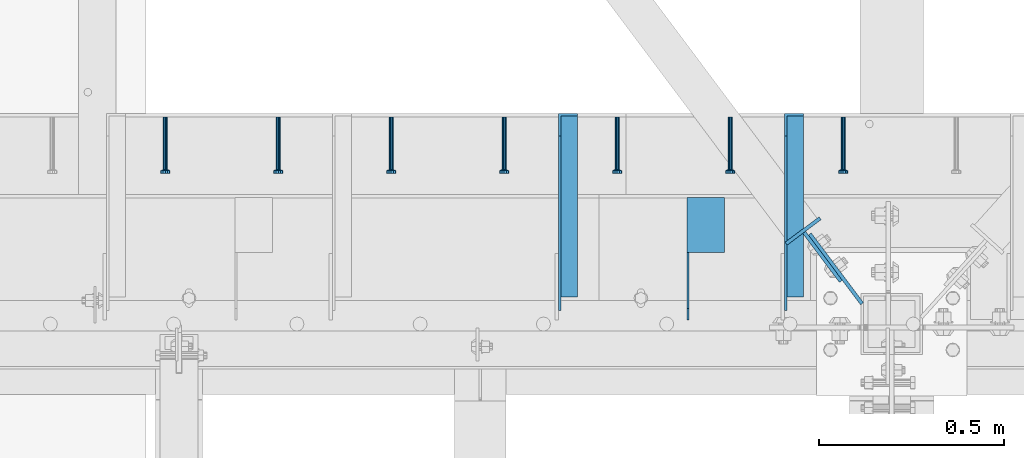
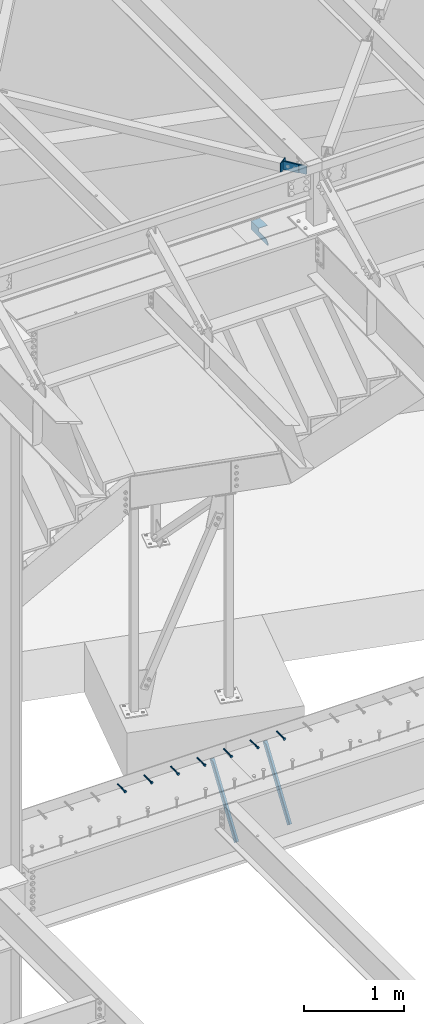
# One storey, part 1372 of 1763: 11 beams, 2 members, 11 elements without a shape of their own.
"""IFC2X3 building model written with IfcOpenShell, lengths in millimetres."""

from ifc_helpers import new_model, si_unit, frame, origin_with_axes, place, context, subcontext, project, spatial, faceted_brep, material, type_object, element, aggregate, save


model = new_model("IFC2X3")

# Units and contexts
model_context = context("Model", 3, precision=1e-05, world=origin_with_axes())
body_context = subcontext(model_context, "Body", "Model", "MODEL_VIEW")
ifc_project = project(units=[si_unit("LENGTHUNIT", "METRE", prefix="MILLI"), si_unit("AREAUNIT", "SQUARE_METRE"), si_unit("VOLUMEUNIT", "CUBIC_METRE"), si_unit("MASSUNIT", "GRAM", prefix="KILO"), si_unit("TIMEUNIT", "SECOND"), si_unit("PLANEANGLEUNIT", "RADIAN"), si_unit("SOLIDANGLEUNIT", "STERADIAN"), si_unit("THERMODYNAMICTEMPERATUREUNIT", "DEGREE_CELSIUS"), si_unit("LUMINOUSINTENSITYUNIT", "LUMEN")], contexts=[model_context])

# Site, building, storey
site_placement = place(None, origin_with_axes())
site = spatial("IfcSite", under=ifc_project, at=site_placement, CompositionType="ELEMENT")
building_placement = place(site_placement, origin_with_axes())
building = spatial("IfcBuilding", under=site, at=building_placement, Name="Undefined", CompositionType="ELEMENT")
storey_placement = place(building_placement, origin_with_axes())
storey = spatial("IfcBuildingStorey", under=building, at=storey_placement, Name="Undefined", CompositionType="ELEMENT", Elevation=0.0)

# Assembly, beam
assembly_1_placement = place(storey_placement, origin_with_axes())
assembly_1 = element("IfcElementAssembly", 1, at=assembly_1_placement, inside=storey, Name="HEADED STUD ANCHOR", AssemblyPlace="NOTDEFINED", PredefinedType="RIGID_FRAME")
ifc_material_1 = material(Name="STEEL/A108")
beam_type_1 = type_object("IfcBeamType", PredefinedType="NOTDEFINED")
beam_1_placement = place(assembly_1_placement, frame((-31240.2466486983, 52679.6000091552, 5264.23140606069), z_axis=(0.0, 0.0, 1.0), x_axis=(0.0, -1.0, 0.0)))
beam_1 = element("IfcBeam", 2, at=beam_1_placement, type_object=beam_type_1, material=ifc_material_1, Name="HEADED STUD ANCHOR", context=body_context, shape_type="Brep", body=[
    faceted_brep([(0.0, -3.1800000667572, 5.5), (0.0, -5.5, 3.1800000667572), (141.732000000002, -5.5, 3.1800000667572), (141.732000000002, -3.1800000667572, 5.5), (0.0, -6.34999999999491, 1.45519152283669e-11), (141.732000000002, -6.34999990463257, 0.0), (0.0, -5.5, -3.1800000667572), (141.732000000002, -5.5, -3.1800000667572), (0.0, -3.1800000667572, -5.5), (141.732000000002, -3.1800000667572, -5.5), (0.0, 0.0, -6.34999990463257), (141.732000000002, 0.0, -6.34999990463257), (0.0, 3.1800000667572, -5.5), (141.732000000002, 3.1800000667572, -5.5), (0.0, 5.5, -3.1800000667572), (141.732000000002, 5.5, -3.1800000667572), (0.0, 6.34999999999491, -2.91038304567337e-11), (141.732000000002, 6.34999990463257, 0.0), (0.0, 5.5, 3.1800000667572), (141.732000000002, 5.5, 3.1800000667572), (0.0, 3.1800000667572, 5.5), (141.732000000002, 3.1800000667572, 5.5), (0.0, 0.0, 6.34999990463257), (141.732000000002, 0.0, 6.34999990463257), (144.780000000001, -10.9899997711182, 6.34999990463257), (144.780000000001, -6.34000015258789, 10.9899997711182), (144.780000000001, -12.6999998092651, 0.0), (144.780000000001, -10.9899997711182, -6.34999990463257), (144.780000000001, -6.34000015258789, -10.9899997711182), (144.780000000001, 0.0, -12.6899995803833), (144.780000000001, 6.34000015258789, -10.9899997711182), (144.780000000001, 10.9899997711182, -6.34999990463257), (144.780000000001, 12.6999998092651, 0.0), (144.780000000001, 10.9899997711182, 6.34999990463257), (144.780000000001, 6.34000015258789, 10.9899997711182), (144.780000000001, 0.0, 12.6899995803833), (152.400000000001, -10.9899997711182, 6.34999990463257), (152.400000000001, -6.34000015258789, 10.9899997711182), (152.400000000001, -12.6999998092651, 0.0), (152.400000000001, -10.9899997711182, -6.34999990463257), (152.400000000001, -6.34000015258789, -10.9899997711182), (152.400000000001, 0.0, -12.6899995803833), (152.400000000001, 6.34000015258789, -10.9899997711182), (152.400000000001, 10.9899997711182, -6.34999990463257), (152.400000000001, 12.6999998092651, 0.0), (152.400000000001, 10.9899997711182, 6.34999990463257), (152.400000000001, 6.34000015258789, 10.9899997711182), (152.400000000001, 0.0, 12.6899995803833)], [[[0, 1, 2, 3]], [[1, 4, 5, 2]], [[4, 6, 7, 5]], [[6, 8, 9, 7]], [[8, 10, 11, 9]], [[10, 12, 13, 11]], [[12, 14, 15, 13]], [[14, 16, 17, 15]], [[16, 18, 19, 17]], [[18, 20, 21, 19]], [[20, 22, 23, 21]], [[22, 0, 3, 23]], [[22, 20, 18, 16, 14, 12, 10, 8, 6, 4, 1, 0]], [[3, 2, 24, 25]], [[2, 5, 26, 24]], [[5, 7, 27, 26]], [[7, 9, 28, 27]], [[9, 11, 29, 28]], [[11, 13, 30, 29]], [[13, 15, 31, 30]], [[15, 17, 32, 31]], [[17, 19, 33, 32]], [[19, 21, 34, 33]], [[21, 23, 35, 34]], [[23, 3, 25, 35]], [[25, 24, 36, 37]], [[24, 26, 38, 36]], [[26, 27, 39, 38]], [[27, 28, 40, 39]], [[28, 29, 41, 40]], [[29, 30, 42, 41]], [[30, 31, 43, 42]], [[31, 32, 44, 43]], [[32, 33, 45, 44]], [[33, 34, 46, 45]], [[34, 35, 47, 46]], [[35, 25, 37, 47]], [[38, 39, 40, 41, 42, 43, 44, 45, 46, 47, 37, 36]]]),
])
aggregate(assembly_1, [beam_1])

assembly_2_placement = place(storey_placement, origin_with_axes())
assembly_2 = element("IfcElementAssembly", 3, at=assembly_2_placement, inside=storey, Name="HEADED STUD ANCHOR", AssemblyPlace="NOTDEFINED", PredefinedType="RIGID_FRAME")
beam_2_placement = place(assembly_2_placement, frame((-31545.0466486983, 52679.6000091552, 5264.23140606069), z_axis=(0.0, 0.0, 1.0), x_axis=(0.0, -1.0, 0.0)))
beam_2 = element("IfcBeam", 4, at=beam_2_placement, type_object=beam_type_1, material=ifc_material_1, Name="HEADED STUD ANCHOR", context=body_context, shape_type="Brep", body=[
    faceted_brep([(0.0, -3.1800000667572, 5.5), (0.0, -5.5, 3.1800000667572), (141.732000000002, -5.5, 3.1800000667572), (141.732000000002, -3.1800000667572, 5.5), (0.0, -6.34999999999491, 1.45519152283669e-11), (141.732000000002, -6.34999990463257, 0.0), (0.0, -5.5, -3.1800000667572), (141.732000000002, -5.5, -3.1800000667572), (0.0, -3.1800000667572, -5.5), (141.732000000002, -3.1800000667572, -5.5), (0.0, 0.0, -6.34999990463257), (141.732000000002, 0.0, -6.34999990463257), (0.0, 3.1800000667572, -5.5), (141.732000000002, 3.1800000667572, -5.5), (0.0, 5.5, -3.1800000667572), (141.732000000002, 5.5, -3.1800000667572), (0.0, 6.34999999999491, -2.91038304567337e-11), (141.732000000002, 6.34999990463257, 0.0), (0.0, 5.5, 3.1800000667572), (141.732000000002, 5.5, 3.1800000667572), (0.0, 3.1800000667572, 5.5), (141.732000000002, 3.1800000667572, 5.5), (0.0, 0.0, 6.34999990463257), (141.732000000002, 0.0, 6.34999990463257), (144.780000000001, -10.9899997711182, 6.34999990463257), (144.780000000001, -6.34000015258789, 10.9899997711182), (144.780000000001, -12.6999998092651, 0.0), (144.780000000001, -10.9899997711182, -6.34999990463257), (144.780000000001, -6.34000015258789, -10.9899997711182), (144.780000000001, 0.0, -12.6899995803833), (144.780000000001, 6.34000015258789, -10.9899997711182), (144.780000000001, 10.9899997711182, -6.34999990463257), (144.780000000001, 12.6999998092651, 0.0), (144.780000000001, 10.9899997711182, 6.34999990463257), (144.780000000001, 6.34000015258789, 10.9899997711182), (144.780000000001, 0.0, 12.6899995803833), (152.400000000001, -10.9899997711182, 6.34999990463257), (152.400000000001, -6.34000015258789, 10.9899997711182), (152.400000000001, -12.6999998092651, 0.0), (152.400000000001, -10.9899997711182, -6.34999990463257), (152.400000000001, -6.34000015258789, -10.9899997711182), (152.400000000001, 0.0, -12.6899995803833), (152.400000000001, 6.34000015258789, -10.9899997711182), (152.400000000001, 10.9899997711182, -6.34999990463257), (152.400000000001, 12.6999998092651, 0.0), (152.400000000001, 10.9899997711182, 6.34999990463257), (152.400000000001, 6.34000015258789, 10.9899997711182), (152.400000000001, 0.0, 12.6899995803833)], [[[0, 1, 2, 3]], [[1, 4, 5, 2]], [[4, 6, 7, 5]], [[6, 8, 9, 7]], [[8, 10, 11, 9]], [[10, 12, 13, 11]], [[12, 14, 15, 13]], [[14, 16, 17, 15]], [[16, 18, 19, 17]], [[18, 20, 21, 19]], [[20, 22, 23, 21]], [[22, 0, 3, 23]], [[22, 20, 18, 16, 14, 12, 10, 8, 6, 4, 1, 0]], [[3, 2, 24, 25]], [[2, 5, 26, 24]], [[5, 7, 27, 26]], [[7, 9, 28, 27]], [[9, 11, 29, 28]], [[11, 13, 30, 29]], [[13, 15, 31, 30]], [[15, 17, 32, 31]], [[17, 19, 33, 32]], [[19, 21, 34, 33]], [[21, 23, 35, 34]], [[23, 3, 25, 35]], [[25, 24, 36, 37]], [[24, 26, 38, 36]], [[26, 27, 39, 38]], [[27, 28, 40, 39]], [[28, 29, 41, 40]], [[29, 30, 42, 41]], [[30, 31, 43, 42]], [[31, 32, 44, 43]], [[32, 33, 45, 44]], [[33, 34, 46, 45]], [[34, 35, 47, 46]], [[35, 25, 37, 47]], [[38, 39, 40, 41, 42, 43, 44, 45, 46, 47, 37, 36]]]),
])
aggregate(assembly_2, [beam_2])

assembly_3_placement = place(storey_placement, origin_with_axes())
assembly_3 = element("IfcElementAssembly", 5, at=assembly_3_placement, inside=storey, Name="HEADED STUD ANCHOR", AssemblyPlace="NOTDEFINED", PredefinedType="RIGID_FRAME")
beam_3_placement = place(assembly_3_placement, frame((-31849.8466486983, 52679.6000091552, 5264.23140606069), z_axis=(0.0, 0.0, 1.0), x_axis=(0.0, -1.0, 0.0)))
beam_3 = element("IfcBeam", 6, at=beam_3_placement, type_object=beam_type_1, material=ifc_material_1, Name="HEADED STUD ANCHOR", context=body_context, shape_type="Brep", body=[
    faceted_brep([(0.0, -3.1800000667572, 5.5), (0.0, -5.5, 3.1800000667572), (141.732000000002, -5.5, 3.1800000667572), (141.732000000002, -3.1800000667572, 5.5), (0.0, -6.34999999999491, 1.45519152283669e-11), (141.732000000002, -6.34999990463257, 0.0), (0.0, -5.5, -3.1800000667572), (141.732000000002, -5.5, -3.1800000667572), (0.0, -3.1800000667572, -5.5), (141.732000000002, -3.1800000667572, -5.5), (0.0, 0.0, -6.34999990463257), (141.732000000002, 0.0, -6.34999990463257), (0.0, 3.1800000667572, -5.5), (141.732000000002, 3.1800000667572, -5.5), (0.0, 5.5, -3.1800000667572), (141.732000000002, 5.5, -3.1800000667572), (0.0, 6.34999999999491, -2.91038304567337e-11), (141.732000000002, 6.34999990463257, 0.0), (0.0, 5.5, 3.1800000667572), (141.732000000002, 5.5, 3.1800000667572), (0.0, 3.1800000667572, 5.5), (141.732000000002, 3.1800000667572, 5.5), (0.0, 0.0, 6.34999990463257), (141.732000000002, 0.0, 6.34999990463257), (144.780000000001, -10.9899997711182, 6.34999990463257), (144.780000000001, -6.34000015258789, 10.9899997711182), (144.780000000001, -12.6999998092651, 0.0), (144.780000000001, -10.9899997711182, -6.34999990463257), (144.780000000001, -6.34000015258789, -10.9899997711182), (144.780000000001, 0.0, -12.6899995803833), (144.780000000001, 6.34000015258789, -10.9899997711182), (144.780000000001, 10.9899997711182, -6.34999990463257), (144.780000000001, 12.6999998092651, 0.0), (144.780000000001, 10.9899997711182, 6.34999990463257), (144.780000000001, 6.34000015258789, 10.9899997711182), (144.780000000001, 0.0, 12.6899995803833), (152.400000000001, -10.9899997711182, 6.34999990463257), (152.400000000001, -6.34000015258789, 10.9899997711182), (152.400000000001, -12.6999998092651, 0.0), (152.400000000001, -10.9899997711182, -6.34999990463257), (152.400000000001, -6.34000015258789, -10.9899997711182), (152.400000000001, 0.0, -12.6899995803833), (152.400000000001, 6.34000015258789, -10.9899997711182), (152.400000000001, 10.9899997711182, -6.34999990463257), (152.400000000001, 12.6999998092651, 0.0), (152.400000000001, 10.9899997711182, 6.34999990463257), (152.400000000001, 6.34000015258789, 10.9899997711182), (152.400000000001, 0.0, 12.6899995803833)], [[[0, 1, 2, 3]], [[1, 4, 5, 2]], [[4, 6, 7, 5]], [[6, 8, 9, 7]], [[8, 10, 11, 9]], [[10, 12, 13, 11]], [[12, 14, 15, 13]], [[14, 16, 17, 15]], [[16, 18, 19, 17]], [[18, 20, 21, 19]], [[20, 22, 23, 21]], [[22, 0, 3, 23]], [[22, 20, 18, 16, 14, 12, 10, 8, 6, 4, 1, 0]], [[3, 2, 24, 25]], [[2, 5, 26, 24]], [[5, 7, 27, 26]], [[7, 9, 28, 27]], [[9, 11, 29, 28]], [[11, 13, 30, 29]], [[13, 15, 31, 30]], [[15, 17, 32, 31]], [[17, 19, 33, 32]], [[19, 21, 34, 33]], [[21, 23, 35, 34]], [[23, 3, 25, 35]], [[25, 24, 36, 37]], [[24, 26, 38, 36]], [[26, 27, 39, 38]], [[27, 28, 40, 39]], [[28, 29, 41, 40]], [[29, 30, 42, 41]], [[30, 31, 43, 42]], [[31, 32, 44, 43]], [[32, 33, 45, 44]], [[33, 34, 46, 45]], [[34, 35, 47, 46]], [[35, 25, 37, 47]], [[38, 39, 40, 41, 42, 43, 44, 45, 46, 47, 37, 36]]]),
])
aggregate(assembly_3, [beam_3])

assembly_4_placement = place(storey_placement, origin_with_axes())
assembly_4 = element("IfcElementAssembly", 7, at=assembly_4_placement, inside=storey, Name="HEADED STUD ANCHOR", AssemblyPlace="NOTDEFINED", PredefinedType="RIGID_FRAME")
beam_4_placement = place(assembly_4_placement, frame((-32154.6466486983, 52679.6000091552, 5264.23140606069), z_axis=(0.0, 0.0, 1.0), x_axis=(0.0, -1.0, 0.0)))
beam_4 = element("IfcBeam", 8, at=beam_4_placement, type_object=beam_type_1, material=ifc_material_1, Name="HEADED STUD ANCHOR", context=body_context, shape_type="Brep", body=[
    faceted_brep([(0.0, -3.1800000667572, 5.5), (0.0, -5.5, 3.1800000667572), (141.732000000002, -5.5, 3.1800000667572), (141.732000000002, -3.1800000667572, 5.5), (0.0, -6.34999999999491, 1.45519152283669e-11), (141.732000000002, -6.34999990463257, 0.0), (0.0, -5.5, -3.1800000667572), (141.732000000002, -5.5, -3.1800000667572), (0.0, -3.1800000667572, -5.5), (141.732000000002, -3.1800000667572, -5.5), (0.0, 0.0, -6.34999990463257), (141.732000000002, 0.0, -6.34999990463257), (0.0, 3.1800000667572, -5.5), (141.732000000002, 3.1800000667572, -5.5), (0.0, 5.5, -3.1800000667572), (141.732000000002, 5.5, -3.1800000667572), (0.0, 6.34999999999491, -2.91038304567337e-11), (141.732000000002, 6.34999990463257, 0.0), (0.0, 5.5, 3.1800000667572), (141.732000000002, 5.5, 3.1800000667572), (0.0, 3.1800000667572, 5.5), (141.732000000002, 3.1800000667572, 5.5), (0.0, 0.0, 6.34999990463257), (141.732000000002, 0.0, 6.34999990463257), (144.780000000001, -10.9899997711182, 6.34999990463257), (144.780000000001, -6.34000015258789, 10.9899997711182), (144.780000000001, -12.6999998092651, 0.0), (144.780000000001, -10.9899997711182, -6.34999990463257), (144.780000000001, -6.34000015258789, -10.9899997711182), (144.780000000001, 0.0, -12.6899995803833), (144.780000000001, 6.34000015258789, -10.9899997711182), (144.780000000001, 10.9899997711182, -6.34999990463257), (144.780000000001, 12.6999998092651, 0.0), (144.780000000001, 10.9899997711182, 6.34999990463257), (144.780000000001, 6.34000015258789, 10.9899997711182), (144.780000000001, 0.0, 12.6899995803833), (152.400000000001, -10.9899997711182, 6.34999990463257), (152.400000000001, -6.34000015258789, 10.9899997711182), (152.400000000001, -12.6999998092651, 0.0), (152.400000000001, -10.9899997711182, -6.34999990463257), (152.400000000001, -6.34000015258789, -10.9899997711182), (152.400000000001, 0.0, -12.6899995803833), (152.400000000001, 6.34000015258789, -10.9899997711182), (152.400000000001, 10.9899997711182, -6.34999990463257), (152.400000000001, 12.6999998092651, 0.0), (152.400000000001, 10.9899997711182, 6.34999990463257), (152.400000000001, 6.34000015258789, 10.9899997711182), (152.400000000001, 0.0, 12.6899995803833)], [[[0, 1, 2, 3]], [[1, 4, 5, 2]], [[4, 6, 7, 5]], [[6, 8, 9, 7]], [[8, 10, 11, 9]], [[10, 12, 13, 11]], [[12, 14, 15, 13]], [[14, 16, 17, 15]], [[16, 18, 19, 17]], [[18, 20, 21, 19]], [[20, 22, 23, 21]], [[22, 0, 3, 23]], [[22, 20, 18, 16, 14, 12, 10, 8, 6, 4, 1, 0]], [[3, 2, 24, 25]], [[2, 5, 26, 24]], [[5, 7, 27, 26]], [[7, 9, 28, 27]], [[9, 11, 29, 28]], [[11, 13, 30, 29]], [[13, 15, 31, 30]], [[15, 17, 32, 31]], [[17, 19, 33, 32]], [[19, 21, 34, 33]], [[21, 23, 35, 34]], [[23, 3, 25, 35]], [[25, 24, 36, 37]], [[24, 26, 38, 36]], [[26, 27, 39, 38]], [[27, 28, 40, 39]], [[28, 29, 41, 40]], [[29, 30, 42, 41]], [[30, 31, 43, 42]], [[31, 32, 44, 43]], [[32, 33, 45, 44]], [[33, 34, 46, 45]], [[34, 35, 47, 46]], [[35, 25, 37, 47]], [[38, 39, 40, 41, 42, 43, 44, 45, 46, 47, 37, 36]]]),
])
aggregate(assembly_4, [beam_4])

assembly_5_placement = place(storey_placement, origin_with_axes())
assembly_5 = element("IfcElementAssembly", 9, at=assembly_5_placement, inside=storey, Name="HEADED STUD ANCHOR", AssemblyPlace="NOTDEFINED", PredefinedType="RIGID_FRAME")
beam_5_placement = place(assembly_5_placement, frame((-32459.4466486983, 52679.6000091552, 5264.23140606069), z_axis=(0.0, 0.0, 1.0), x_axis=(0.0, -1.0, 0.0)))
beam_5 = element("IfcBeam", 10, at=beam_5_placement, type_object=beam_type_1, material=ifc_material_1, Name="HEADED STUD ANCHOR", context=body_context, shape_type="Brep", body=[
    faceted_brep([(0.0, -3.1800000667572, 5.5), (0.0, -5.5, 3.1800000667572), (141.732000000002, -5.5, 3.1800000667572), (141.732000000002, -3.1800000667572, 5.5), (0.0, -6.34999999999491, 1.45519152283669e-11), (141.732000000002, -6.34999990463257, 0.0), (0.0, -5.5, -3.1800000667572), (141.732000000002, -5.5, -3.1800000667572), (0.0, -3.1800000667572, -5.5), (141.732000000002, -3.1800000667572, -5.5), (0.0, 0.0, -6.34999990463257), (141.732000000002, 0.0, -6.34999990463257), (0.0, 3.1800000667572, -5.5), (141.732000000002, 3.1800000667572, -5.5), (0.0, 5.5, -3.1800000667572), (141.732000000002, 5.5, -3.1800000667572), (0.0, 6.34999999999491, -2.91038304567337e-11), (141.732000000002, 6.34999990463257, 0.0), (0.0, 5.5, 3.1800000667572), (141.732000000002, 5.5, 3.1800000667572), (0.0, 3.1800000667572, 5.5), (141.732000000002, 3.1800000667572, 5.5), (0.0, 0.0, 6.34999990463257), (141.732000000002, 0.0, 6.34999990463257), (144.780000000001, -10.9899997711182, 6.34999990463257), (144.780000000001, -6.34000015258789, 10.9899997711182), (144.780000000001, -12.6999998092651, 0.0), (144.780000000001, -10.9899997711182, -6.34999990463257), (144.780000000001, -6.34000015258789, -10.9899997711182), (144.780000000001, 0.0, -12.6899995803833), (144.780000000001, 6.34000015258789, -10.9899997711182), (144.780000000001, 10.9899997711182, -6.34999990463257), (144.780000000001, 12.6999998092651, 0.0), (144.780000000001, 10.9899997711182, 6.34999990463257), (144.780000000001, 6.34000015258789, 10.9899997711182), (144.780000000001, 0.0, 12.6899995803833), (152.400000000001, -10.9899997711182, 6.34999990463257), (152.400000000001, -6.34000015258789, 10.9899997711182), (152.400000000001, -12.6999998092651, 0.0), (152.400000000001, -10.9899997711182, -6.34999990463257), (152.400000000001, -6.34000015258789, -10.9899997711182), (152.400000000001, 0.0, -12.6899995803833), (152.400000000001, 6.34000015258789, -10.9899997711182), (152.400000000001, 10.9899997711182, -6.34999990463257), (152.400000000001, 12.6999998092651, 0.0), (152.400000000001, 10.9899997711182, 6.34999990463257), (152.400000000001, 6.34000015258789, 10.9899997711182), (152.400000000001, 0.0, 12.6899995803833)], [[[0, 1, 2, 3]], [[1, 4, 5, 2]], [[4, 6, 7, 5]], [[6, 8, 9, 7]], [[8, 10, 11, 9]], [[10, 12, 13, 11]], [[12, 14, 15, 13]], [[14, 16, 17, 15]], [[16, 18, 19, 17]], [[18, 20, 21, 19]], [[20, 22, 23, 21]], [[22, 0, 3, 23]], [[22, 20, 18, 16, 14, 12, 10, 8, 6, 4, 1, 0]], [[3, 2, 24, 25]], [[2, 5, 26, 24]], [[5, 7, 27, 26]], [[7, 9, 28, 27]], [[9, 11, 29, 28]], [[11, 13, 30, 29]], [[13, 15, 31, 30]], [[15, 17, 32, 31]], [[17, 19, 33, 32]], [[19, 21, 34, 33]], [[21, 23, 35, 34]], [[23, 3, 25, 35]], [[25, 24, 36, 37]], [[24, 26, 38, 36]], [[26, 27, 39, 38]], [[27, 28, 40, 39]], [[28, 29, 41, 40]], [[29, 30, 42, 41]], [[30, 31, 43, 42]], [[31, 32, 44, 43]], [[32, 33, 45, 44]], [[33, 34, 46, 45]], [[34, 35, 47, 46]], [[35, 25, 37, 47]], [[38, 39, 40, 41, 42, 43, 44, 45, 46, 47, 37, 36]]]),
])
aggregate(assembly_5, [beam_5])

assembly_6_placement = place(storey_placement, origin_with_axes())
assembly_6 = element("IfcElementAssembly", 11, at=assembly_6_placement, inside=storey, Name="HEADED STUD ANCHOR", AssemblyPlace="NOTDEFINED", PredefinedType="RIGID_FRAME")
beam_6_placement = place(assembly_6_placement, frame((-32764.2466486983, 52679.6000091552, 5264.23140606069), z_axis=(0.0, 0.0, 1.0), x_axis=(0.0, -1.0, 0.0)))
beam_6 = element("IfcBeam", 12, at=beam_6_placement, type_object=beam_type_1, material=ifc_material_1, Name="HEADED STUD ANCHOR", context=body_context, shape_type="Brep", body=[
    faceted_brep([(0.0, -3.1800000667572, 5.5), (0.0, -5.5, 3.1800000667572), (141.732000000002, -5.5, 3.1800000667572), (141.732000000002, -3.1800000667572, 5.5), (0.0, -6.34999999999491, 1.45519152283669e-11), (141.732000000002, -6.34999990463257, 0.0), (0.0, -5.5, -3.1800000667572), (141.732000000002, -5.5, -3.1800000667572), (0.0, -3.1800000667572, -5.5), (141.732000000002, -3.1800000667572, -5.5), (0.0, 0.0, -6.34999990463257), (141.732000000002, 0.0, -6.34999990463257), (0.0, 3.1800000667572, -5.5), (141.732000000002, 3.1800000667572, -5.5), (0.0, 5.5, -3.1800000667572), (141.732000000002, 5.5, -3.1800000667572), (0.0, 6.34999999999491, -2.91038304567337e-11), (141.732000000002, 6.34999990463257, 0.0), (0.0, 5.5, 3.1800000667572), (141.732000000002, 5.5, 3.1800000667572), (0.0, 3.1800000667572, 5.5), (141.732000000002, 3.1800000667572, 5.5), (0.0, 0.0, 6.34999990463257), (141.732000000002, 0.0, 6.34999990463257), (144.780000000001, -10.9899997711182, 6.34999990463257), (144.780000000001, -6.34000015258789, 10.9899997711182), (144.780000000001, -12.6999998092651, 0.0), (144.780000000001, -10.9899997711182, -6.34999990463257), (144.780000000001, -6.34000015258789, -10.9899997711182), (144.780000000001, 0.0, -12.6899995803833), (144.780000000001, 6.34000015258789, -10.9899997711182), (144.780000000001, 10.9899997711182, -6.34999990463257), (144.780000000001, 12.6999998092651, 0.0), (144.780000000001, 10.9899997711182, 6.34999990463257), (144.780000000001, 6.34000015258789, 10.9899997711182), (144.780000000001, 0.0, 12.6899995803833), (152.400000000001, -10.9899997711182, 6.34999990463257), (152.400000000001, -6.34000015258789, 10.9899997711182), (152.400000000001, -12.6999998092651, 0.0), (152.400000000001, -10.9899997711182, -6.34999990463257), (152.400000000001, -6.34000015258789, -10.9899997711182), (152.400000000001, 0.0, -12.6899995803833), (152.400000000001, 6.34000015258789, -10.9899997711182), (152.400000000001, 10.9899997711182, -6.34999990463257), (152.400000000001, 12.6999998092651, 0.0), (152.400000000001, 10.9899997711182, 6.34999990463257), (152.400000000001, 6.34000015258789, 10.9899997711182), (152.400000000001, 0.0, 12.6899995803833)], [[[0, 1, 2, 3]], [[1, 4, 5, 2]], [[4, 6, 7, 5]], [[6, 8, 9, 7]], [[8, 10, 11, 9]], [[10, 12, 13, 11]], [[12, 14, 15, 13]], [[14, 16, 17, 15]], [[16, 18, 19, 17]], [[18, 20, 21, 19]], [[20, 22, 23, 21]], [[22, 0, 3, 23]], [[22, 20, 18, 16, 14, 12, 10, 8, 6, 4, 1, 0]], [[3, 2, 24, 25]], [[2, 5, 26, 24]], [[5, 7, 27, 26]], [[7, 9, 28, 27]], [[9, 11, 29, 28]], [[11, 13, 30, 29]], [[13, 15, 31, 30]], [[15, 17, 32, 31]], [[17, 19, 33, 32]], [[19, 21, 34, 33]], [[21, 23, 35, 34]], [[23, 3, 25, 35]], [[25, 24, 36, 37]], [[24, 26, 38, 36]], [[26, 27, 39, 38]], [[27, 28, 40, 39]], [[28, 29, 41, 40]], [[29, 30, 42, 41]], [[30, 31, 43, 42]], [[31, 32, 44, 43]], [[32, 33, 45, 44]], [[33, 34, 46, 45]], [[34, 35, 47, 46]], [[35, 25, 37, 47]], [[38, 39, 40, 41, 42, 43, 44, 45, 46, 47, 37, 36]]]),
])
aggregate(assembly_6, [beam_6])

assembly_7_placement = place(storey_placement, origin_with_axes())
assembly_7 = element("IfcElementAssembly", 13, at=assembly_7_placement, inside=storey, Name="HEADED STUD ANCHOR", AssemblyPlace="NOTDEFINED", PredefinedType="RIGID_FRAME")
beam_7_placement = place(assembly_7_placement, frame((-33069.0466486983, 52679.6000091552, 5264.23140606069), z_axis=(0.0, 0.0, 1.0), x_axis=(0.0, -1.0, 0.0)))
beam_7 = element("IfcBeam", 14, at=beam_7_placement, type_object=beam_type_1, material=ifc_material_1, Name="HEADED STUD ANCHOR", context=body_context, shape_type="Brep", body=[
    faceted_brep([(0.0, -3.1800000667572, 5.5), (0.0, -5.5, 3.1800000667572), (141.732000000002, -5.5, 3.1800000667572), (141.732000000002, -3.1800000667572, 5.5), (0.0, -6.34999999999491, 1.45519152283669e-11), (141.732000000002, -6.34999990463257, 0.0), (0.0, -5.5, -3.1800000667572), (141.732000000002, -5.5, -3.1800000667572), (0.0, -3.1800000667572, -5.5), (141.732000000002, -3.1800000667572, -5.5), (0.0, 0.0, -6.34999990463257), (141.732000000002, 0.0, -6.34999990463257), (0.0, 3.1800000667572, -5.5), (141.732000000002, 3.1800000667572, -5.5), (0.0, 5.5, -3.1800000667572), (141.732000000002, 5.5, -3.1800000667572), (0.0, 6.34999999999491, -2.91038304567337e-11), (141.732000000002, 6.34999990463257, 0.0), (0.0, 5.5, 3.1800000667572), (141.732000000002, 5.5, 3.1800000667572), (0.0, 3.1800000667572, 5.5), (141.732000000002, 3.1800000667572, 5.5), (0.0, 0.0, 6.34999990463257), (141.732000000002, 0.0, 6.34999990463257), (144.780000000001, -10.9899997711182, 6.34999990463257), (144.780000000001, -6.34000015258789, 10.9899997711182), (144.780000000001, -12.6999998092651, 0.0), (144.780000000001, -10.9899997711182, -6.34999990463257), (144.780000000001, -6.34000015258789, -10.9899997711182), (144.780000000001, 0.0, -12.6899995803833), (144.780000000001, 6.34000015258789, -10.9899997711182), (144.780000000001, 10.9899997711182, -6.34999990463257), (144.780000000001, 12.6999998092651, 0.0), (144.780000000001, 10.9899997711182, 6.34999990463257), (144.780000000001, 6.34000015258789, 10.9899997711182), (144.780000000001, 0.0, 12.6899995803833), (152.400000000001, -10.9899997711182, 6.34999990463257), (152.400000000001, -6.34000015258789, 10.9899997711182), (152.400000000001, -12.6999998092651, 0.0), (152.400000000001, -10.9899997711182, -6.34999990463257), (152.400000000001, -6.34000015258789, -10.9899997711182), (152.400000000001, 0.0, -12.6899995803833), (152.400000000001, 6.34000015258789, -10.9899997711182), (152.400000000001, 10.9899997711182, -6.34999990463257), (152.400000000001, 12.6999998092651, 0.0), (152.400000000001, 10.9899997711182, 6.34999990463257), (152.400000000001, 6.34000015258789, 10.9899997711182), (152.400000000001, 0.0, 12.6899995803833)], [[[0, 1, 2, 3]], [[1, 4, 5, 2]], [[4, 6, 7, 5]], [[6, 8, 9, 7]], [[8, 10, 11, 9]], [[10, 12, 13, 11]], [[12, 14, 15, 13]], [[14, 16, 17, 15]], [[16, 18, 19, 17]], [[18, 20, 21, 19]], [[20, 22, 23, 21]], [[22, 0, 3, 23]], [[22, 20, 18, 16, 14, 12, 10, 8, 6, 4, 1, 0]], [[3, 2, 24, 25]], [[2, 5, 26, 24]], [[5, 7, 27, 26]], [[7, 9, 28, 27]], [[9, 11, 29, 28]], [[11, 13, 30, 29]], [[13, 15, 31, 30]], [[15, 17, 32, 31]], [[17, 19, 33, 32]], [[19, 21, 34, 33]], [[21, 23, 35, 34]], [[23, 3, 25, 35]], [[25, 24, 36, 37]], [[24, 26, 38, 36]], [[26, 27, 39, 38]], [[27, 28, 40, 39]], [[28, 29, 41, 40]], [[29, 30, 42, 41]], [[30, 31, 43, 42]], [[31, 32, 44, 43]], [[32, 33, 45, 44]], [[33, 34, 46, 45]], [[34, 35, 47, 46]], [[35, 25, 37, 47]], [[38, 39, 40, 41, 42, 43, 44, 45, 46, 47, 37, 36]]]),
])
aggregate(assembly_7, [beam_7])

# Assembly, members
assembly_8_placement = place(storey_placement, origin_with_axes())
assembly_8 = element("IfcElementAssembly", 15, at=assembly_8_placement, inside=storey, Name="BEAM", AssemblyPlace="NOTDEFINED", PredefinedType="RIGID_FRAME")
ifc_material_2 = material(Name="STEEL/A36")
member_type = type_object("IfcMemberType", Name="L2X2X1/4", PredefinedType="NOTDEFINED")
member_1_placement = place(assembly_8_placement, frame((-31373.0370109278, 52177.7789126344, 4484.66874800095), z_axis=(0.0, -0.827940419190063, 0.560816068128742), x_axis=(0.0, 0.560816068128741, 0.827940419190064)))
member_1 = element("IfcMember", 16, at=member_1_placement, type_object=member_type, material=ifc_material_2, Name="ANGLE", ObjectType="L2X2X1/4", context=body_context, shape_type="Brep", body=[
    faceted_brep([(-1.45519152283669e-11, 25.4000000000015, -25.3999999999869), (1.45519152283669e-11, 25.4000000000015, 25.3999999999796), (839.899233991324, 25.4000000000015, 25.3999999994412), (874.309265921926, 25.4000000000015, -25.4000000006854), (1.45519152283669e-11, 19.0499999999993, 25.3999999999796), (839.899233991324, 19.0499999999993, 25.3999999994412), (-7.27595761418343e-12, 19.0499999999993, -19.0499999999956), (870.0080119306, 19.0499999999993, -19.0500000006723), (-7.27595761418343e-12, -25.4000000000015, -19.0499999999956), (870.0080119306, -25.4000000000015, -19.0500000006723), (-1.45519152283669e-11, -25.4000000000015, -25.3999999999869), (874.309265921926, -25.4000000000015, -25.4000000006854)], [[[0, 1, 2, 3]], [[1, 4, 5, 2]], [[4, 6, 7, 5]], [[6, 8, 9, 7]], [[8, 10, 11, 9]], [[10, 0, 3, 11]], [[5, 7, 9, 11, 3, 2]], [[10, 8, 6, 4, 1, 0]]]),
])
member_2_placement = place(assembly_8_placement, frame((-31982.6370109278, 52177.7789126344, 4484.66874800095), z_axis=(0.0, -0.827940419190063, 0.560816068128742), x_axis=(0.0, 0.560816068128741, 0.827940419190064)))
member_2 = element("IfcMember", 17, at=member_2_placement, type_object=member_type, material=ifc_material_2, Name="ANGLE", ObjectType="L2X2X1/4", context=body_context, shape_type="Brep", body=[
    faceted_brep([(-1.45519152283669e-11, 25.4000000000015, -25.3999999999869), (1.45519152283669e-11, 25.4000000000015, 25.3999999999796), (839.899233991324, 25.4000000000015, 25.3999999994412), (874.309265921926, 25.4000000000015, -25.4000000006854), (1.45519152283669e-11, 19.0499999999993, 25.3999999999796), (839.899233991324, 19.0499999999993, 25.3999999994412), (-7.27595761418343e-12, 19.0499999999993, -19.0499999999956), (870.0080119306, 19.0499999999993, -19.0500000006723), (-7.27595761418343e-12, -25.4000000000015, -19.0499999999956), (870.0080119306, -25.4000000000015, -19.0500000006723), (-1.45519152283669e-11, -25.4000000000015, -25.3999999999869), (874.309265921926, -25.4000000000015, -25.4000000006854)], [[[0, 1, 2, 3]], [[1, 4, 5, 2]], [[4, 6, 7, 5]], [[6, 8, 9, 7]], [[8, 10, 11, 9]], [[10, 0, 3, 11]], [[5, 7, 9, 11, 3, 2]], [[10, 8, 6, 4, 1, 0]]]),
])
aggregate(assembly_8, [member_1, member_2])

# Assembly, beam
assembly_9_placement = place(storey_placement, origin_with_axes())
assembly_9 = element("IfcElementAssembly", 18, at=assembly_9_placement, inside=storey, Name="BEAM", AssemblyPlace="NOTDEFINED", PredefinedType="RIGID_FRAME")
beam_type_2 = type_object("IfcBeamType", Name="L4X4X1/4", PredefinedType="NOTDEFINED")
beam_8_placement = place(assembly_9_placement, frame((-31611.3247736984, 52462.1124819023, 11696.6999917654), z_axis=(0.0, 0.0, -1.0), x_axis=(0.0, -1.0, 0.0)))
beam_8 = element("IfcBeam", 19, at=beam_8_placement, type_object=beam_type_2, material=ifc_material_2, Name="BRACE", ObjectType="L4X4X1/4", context=body_context, shape_type="Brep", body=[
    faceted_brep([(148.43173432786, 44.4500000000007, -44.4500000000007), (148.431790430077, -50.7999999999993, -44.4500000000007), (148.431790785675, -50.7999999999993, -50.7999999999993), (148.43173094331, 50.7999999999993, -50.7999999999993), (148.431728809323, 50.7999999999993, -12.6999970794623), (148.431732549492, 44.4500000000007, -12.6999970794623), (299.243731689443, 50.7999999999993, -12.7000043904281), (299.243731689443, 44.4499999999971, -12.7000043904281), (2.11002770811319e-10, -50.8000000000357, -50.799999999952), (1.96450855582952e-10, -50.8000000000338, -44.4499999999534), (-2.18278728425503e-11, 44.4500000000007, -44.450000000048), (-1.81898940354586e-10, 44.4500000000371, 50.7999999999374), (-1.96450855582952e-10, 50.8000000000393, 50.7999999999374), (-3.63797880709171e-11, 50.8000000000011, -50.8000000000538), (330.993731689443, 44.4500000000007, 50.7999999999993), (330.993731689443, 50.7999999999993, 50.7999999999993), (330.993731689443, 44.4500000000007, 19.050000000012), (330.993731689443, 50.7999999999993, 19.050000000012)], [[[0, 1, 2, 3, 4, 5]], [[5, 4, 6, 7]], [[8, 9, 10, 11, 12, 13]], [[12, 11, 14, 15]], [[15, 14, 16, 17]], [[16, 7, 6, 17]], [[4, 3, 13, 12, 15, 17, 6]], [[8, 13, 3, 2]], [[9, 8, 2, 1]], [[10, 9, 1, 0]], [[14, 11, 10, 0, 5, 7, 16]]]),
])
aggregate(assembly_9, [beam_8])

assembly_10_placement = place(storey_placement, origin_with_axes())
assembly_10 = element("IfcElementAssembly", 20, at=assembly_10_placement, inside=storey, Name="COLUMN", AssemblyPlace="NOTDEFINED", PredefinedType="RIGID_FRAME")
beam_type_3 = type_object("IfcBeamType", PredefinedType="NOTDEFINED")
beam_9_placement = place(assembly_10_placement, frame((-31259.7598785094, 52269.7047489595, 12422.1875), z_axis=(0.599563330174935, -0.800327316233515, 0.0), x_axis=(0.0, 0.0, -1.0)))
beam_9 = element("IfcBeam", 21, at=beam_9_placement, type_object=beam_type_3, material=ifc_material_2, Name="PLATE", context=body_context, shape_type="Brep", body=[
    faceted_brep([(0.0, 4.76249999984248, -117.474999999904), (0.0, 4.76250000013351, 117.474999999919), (101.599999999999, 4.76250000013351, 117.474999999919), (101.599999999999, 4.76249999984248, -117.474999999904), (0.0, -4.76249999983884, 117.474999999904), (101.599999999999, -4.76249999983884, 117.474999999904), (0.0, -4.76250000012988, -117.474999999911), (101.599999999999, -4.76250000012988, -117.474999999911)], [[[0, 1, 2, 3]], [[1, 4, 5, 2]], [[4, 6, 7, 5]], [[6, 0, 3, 7]], [[5, 7, 3, 2]], [[6, 4, 1, 0]]]),
])
aggregate(assembly_10, [beam_9])

# Assembly, beams
assembly_11_placement = place(storey_placement, origin_with_axes())
assembly_11 = element("IfcElementAssembly", 22, at=assembly_11_placement, inside=storey, Name="H. BRACE", AssemblyPlace="NOTDEFINED", PredefinedType="RIGID_FRAME")
beam_10_placement = place(assembly_11_placement, frame((-31295.9242047068, 52302.0921501726, 12422.1875), z_axis=(0.599563330174935, -0.800327316233515, 0.0), x_axis=(0.0, 0.0, -1.0)))
beam_10 = element("IfcBeam", 23, at=beam_10_placement, type_object=beam_type_3, material=ifc_material_2, Name="PLATE", context=body_context, shape_type="Brep", body=[
    faceted_brep([(0.0, 4.7625000001417, -82.5500000001048), (0.0, 4.76249999986885, 82.5500000001339), (101.599999999999, 4.76249999986885, 82.5500000001339), (101.599999999999, 4.7625000001417, -82.5500000001048), (0.0, -4.76250000014352, 82.5500000001193), (101.599999999999, -4.76250000014352, 82.5500000001193), (0.0, -4.76249999987067, -82.5500000001193), (101.599999999999, -4.76249999987067, -82.5500000001193)], [[[0, 1, 2, 3]], [[1, 4, 5, 2]], [[4, 6, 7, 5]], [[6, 0, 3, 7]], [[5, 7, 3, 2]], [[6, 4, 1, 0]]]),
])
beam_type_4 = type_object("IfcBeamType", PredefinedType="NOTDEFINED")
beam_11_placement = place(assembly_11_placement, frame((-31348.273577973, 52371.9707289709, 12428.5375), z_axis=(0.800327316233517, 0.599563330174933, 0.0), x_axis=(0.0, 0.0, -1.0)))
beam_11 = element("IfcBeam", 24, at=beam_11_placement, type_object=beam_type_4, material=ifc_material_2, Name="PLATE", context=body_context, shape_type="Brep", body=[
    faceted_brep([(0.0, 4.76249999989523, -57.1500000001702), (0.0, 4.76250000014261, 57.1500000001565), (114.299999999999, 4.76250000014261, 57.1500000001565), (114.299999999999, 4.76249999989523, -57.1500000001702), (0.0, -4.76249999988067, 57.1500000001784), (114.299999999999, -4.76249999988067, 57.1500000001784), (0.0, -4.76250000012806, -57.150000000152), (114.299999999999, -4.76250000012806, -57.150000000152)], [[[0, 1, 2, 3]], [[1, 4, 5, 2]], [[4, 6, 7, 5]], [[6, 0, 3, 7]], [[5, 7, 3, 2]], [[6, 4, 1, 0]]]),
])
aggregate(assembly_11, [beam_11, beam_10])

save(model, "model.ifc")
